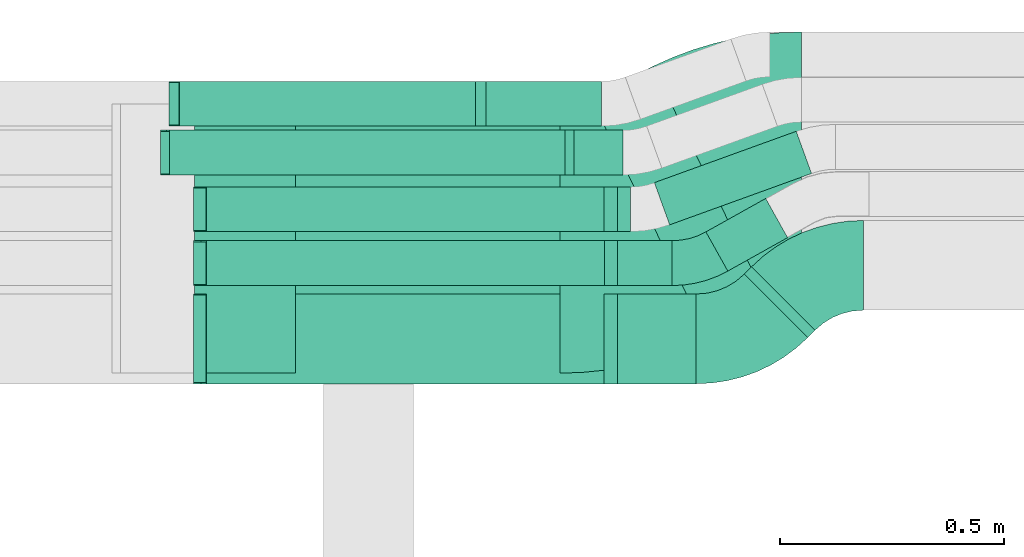
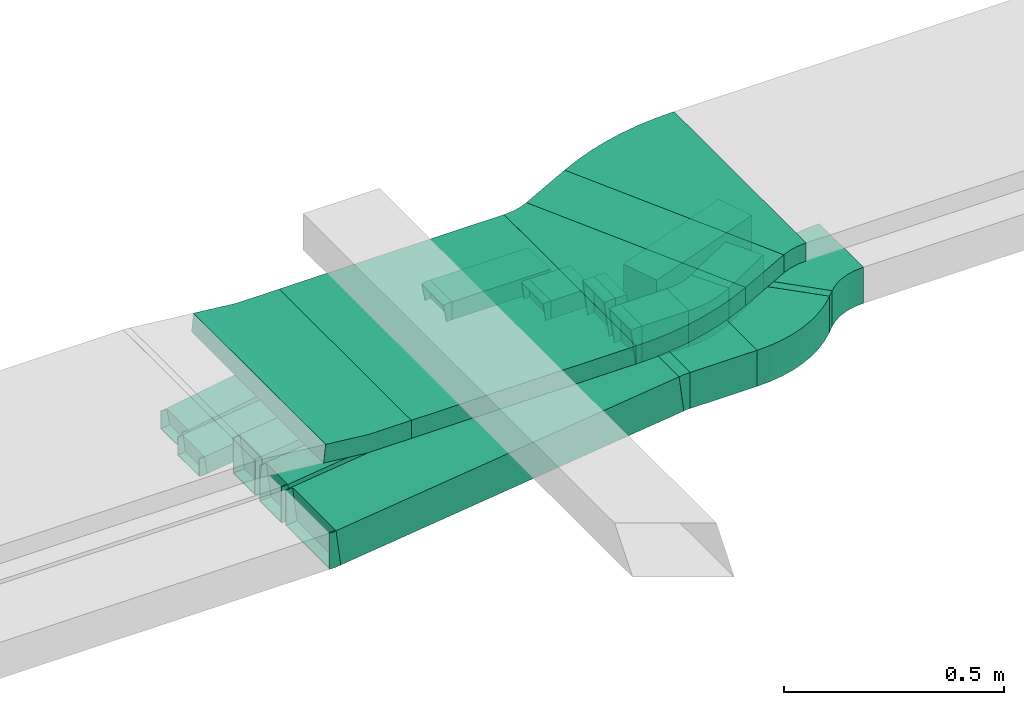
# One storey, part 26 of 38: 16 flow fittings, 15 flow segments.
"""IFC2X3 building model written with IfcOpenShell, lengths in millimetres."""

from ifc_helpers import new_model, entity, si_unit, converted_unit, derived_unit, direction, frame, frame_2d, origin, origin_2d_with_axis, place, context, subcontext, project, spatial, polyline, circle_curve, parameter, trimmed, segment, composite_curve, rectangle, outline, extrude, faceted_brep, source, transform, mapped, material, type_object, type_shapes, element, save


model = new_model("IFC2X3")

# Units and contexts
model_context = context("Model", 3, precision=0.01, world=origin(), true_north=direction((6.12303176911189e-17, 1.0)))
body_context = subcontext(model_context, "Body", "Model", "MODEL_VIEW")
ifc_project = project(units=[si_unit("LENGTHUNIT", "METRE", prefix="MILLI"), si_unit("AREAUNIT", "SQUARE_METRE"), si_unit("VOLUMEUNIT", "CUBIC_METRE"), converted_unit("PLANEANGLEUNIT", "DEGREE", entity("IfcRatioMeasure", 0.0174532925199433), si_unit("PLANEANGLEUNIT", "RADIAN"), dimensions=[0, 0, 0, 0, 0, 0, 0]), si_unit("MASSUNIT", "GRAM", prefix="KILO"), derived_unit("MASSDENSITYUNIT", [(si_unit("MASSUNIT", "GRAM", prefix="KILO"), 1), (si_unit("LENGTHUNIT", "METRE"), -3)]), derived_unit("MOMENTOFINERTIAUNIT", [(si_unit("LENGTHUNIT", "METRE"), 4)]), si_unit("TIMEUNIT", "SECOND"), si_unit("FREQUENCYUNIT", "HERTZ"), si_unit("THERMODYNAMICTEMPERATUREUNIT", "DEGREE_CELSIUS"), derived_unit("THERMALTRANSMITTANCEUNIT", [(si_unit("MASSUNIT", "GRAM", prefix="KILO"), 1), (si_unit("THERMODYNAMICTEMPERATUREUNIT", "KELVIN"), -1), (si_unit("TIMEUNIT", "SECOND"), -3)]), derived_unit("VOLUMETRICFLOWRATEUNIT", [(si_unit("LENGTHUNIT", "METRE"), 3), (si_unit("TIMEUNIT", "SECOND"), -1)]), derived_unit("MASSFLOWRATEUNIT", [(si_unit("MASSUNIT", "GRAM", prefix="KILO"), 1), (si_unit("TIMEUNIT", "SECOND"), -1)]), derived_unit("ROTATIONALFREQUENCYUNIT", [(si_unit("TIMEUNIT", "SECOND"), -1)]), si_unit("ELECTRICCURRENTUNIT", "AMPERE"), si_unit("ELECTRICVOLTAGEUNIT", "VOLT"), si_unit("POWERUNIT", "WATT"), si_unit("FORCEUNIT", "NEWTON", prefix="KILO"), si_unit("ILLUMINANCEUNIT", "LUX"), si_unit("LUMINOUSFLUXUNIT", "LUMEN"), si_unit("LUMINOUSINTENSITYUNIT", "CANDELA"), derived_unit("USERDEFINED", [(si_unit("MASSUNIT", "GRAM", prefix="KILO"), -1), (si_unit("LENGTHUNIT", "METRE"), -2), (si_unit("TIMEUNIT", "SECOND"), 3), (si_unit("LUMINOUSFLUXUNIT", "LUMEN"), 1)]), derived_unit("LINEARVELOCITYUNIT", [(si_unit("LENGTHUNIT", "METRE"), 1), (si_unit("TIMEUNIT", "SECOND"), -1)]), si_unit("PRESSUREUNIT", "PASCAL"), derived_unit("USERDEFINED", [(si_unit("LENGTHUNIT", "METRE"), -2), (si_unit("MASSUNIT", "GRAM", prefix="KILO"), 1), (si_unit("TIMEUNIT", "SECOND"), -2)]), derived_unit("LINEARFORCEUNIT", [(si_unit("MASSUNIT", "GRAM", prefix="KILO"), 1), (si_unit("LENGTHUNIT", "METRE"), 1), (si_unit("TIMEUNIT", "SECOND"), -2), (si_unit("LENGTHUNIT", "METRE"), -1)]), derived_unit("PLANARFORCEUNIT", [(si_unit("MASSUNIT", "GRAM", prefix="KILO"), 1), (si_unit("LENGTHUNIT", "METRE"), 1), (si_unit("TIMEUNIT", "SECOND"), -2), (si_unit("LENGTHUNIT", "METRE"), -2)])], contexts=[model_context])

# Site, building, storey
site_placement = place(None, frame((0.0, -0.00077364408347762, 0.0)))
site = spatial("IfcSite", under=ifc_project, at=site_placement, CompositionType="ELEMENT")
building_placement = place(site_placement, origin())
building = spatial("IfcBuilding", under=site, at=building_placement, CompositionType="ELEMENT")
storey_placement = place(building_placement, frame((0.0, 0.0, 4200.0)))
storey = spatial("IfcBuildingStorey", under=building, at=storey_placement, CompositionType="ELEMENT", Elevation=4200.0)

# Flow segments
cable_carrier_segment_type = type_object("IfcCableCarrierSegmentType", PredefinedType="CABLETRAYSEGMENT")
flow_segment_1_placement = place(storey_placement, frame((26151.9498084436, 15455.6878366683, 2793.21248393464)))
element("IfcFlowSegment", 1, at=flow_segment_1_placement, inside=storey, type_object=cable_carrier_segment_type, context=body_context, shape_type="SweptSolid", body=[
    extrude(rectangle(XDim=155.206153219677, YDim=600.0, at=origin_2d_with_axis()), frame((201.260527268146, 303.657163577565, 0.0), z_axis=(0.0, 0.0, 1.0), x_axis=(-0.898794046299167, -0.438371146789078, 0.0)), (0.0, 0.0, 1.0), 49.9999999999995),
])
flow_segment_2_placement = place(storey_placement, frame((25495.2448252932, 15379.3450002459, 2793.21248393464)))
element("IfcFlowSegment", 2, at=flow_segment_2_placement, inside=storey, type_object=cable_carrier_segment_type, context=body_context, shape_type="SweptSolid", body=[
    extrude(rectangle(XDim=589.05051708577, YDim=599.999999999998, at=frame_2d((2.18847162614111e-12, 0.0), x_axis=(1.0, 0.0))), frame((294.525258542883, 300.0, 0.0), z_axis=(0.0, 0.0, 1.0), x_axis=(-1.0, 0.0, 0.0)), (0.0, 0.0, 1.0), 49.9999999999995),
])
flow_segment_3_placement = place(storey_placement, frame((26495.4909974852, 15458.8827030652, 2639.20628594082)))
element("IfcFlowSegment", 3, at=flow_segment_3_placement, inside=storey, type_object=cable_carrier_segment_type, context=body_context, shape_type="SweptSolid", body=[
    extrude(rectangle(XDim=22.5844049492806, YDim=199.999999999995, at=frame_2d((-1.53121959556302e-12, 1.53477230924182e-12), x_axis=(1.0, 0.0))), frame((78.6954710630032, 78.6954710630032, 0.0), z_axis=(0.0, 0.0, 1.0), x_axis=(-0.707106781186596, -0.7071067811865, 0.0)), (0.0, 0.0, 1.0), 99.9999999999989),
])
flow_segment_4_placement = place(storey_placement, frame((26212.272261474, 15355.6629696993, 2639.20628594082)))
element("IfcFlowSegment", 4, at=flow_segment_4_placement, inside=storey, type_object=cable_carrier_segment_type, context=body_context, shape_type="SweptSolid", body=[
    extrude(rectangle(XDim=175.445612052065, YDim=200.000000000002, at=frame_2d((-2.16715534406831e-12, 2.16715534406831e-12), x_axis=(1.0, 0.0))), frame((87.7228060260303, 100.0, 0.0), z_axis=(0.0, 0.0, 1.0), x_axis=(-1.0, 0.0, 0.0)), (0.0, 0.0, 1.0), 99.9999999999989),
])
flow_segment_5_placement = place(storey_placement, frame((25284.2385665113, 15355.6629696993, 2526.29504881658)))
element("IfcFlowSegment", 5, at=flow_segment_5_placement, inside=storey, type_object=cable_carrier_segment_type, context=body_context, shape_type="SweptSolid", body=[
    extrude(rectangle(XDim=99.9999999999987, YDim=200.000000000002, at=frame_2d((-2.16715534406831e-12, 0.0), x_axis=(0.0, 1.0))), frame((6.17491527178125, 100.0, 49.6172391552196), z_axis=(0.992344783104405, 0.0, 0.123498305435627), x_axis=(0.0, 1.0, 0.0)), (0.0, 0.0, 1.0), 905.864321564183),
])
flow_segment_6_placement = place(storey_placement, frame((26212.802469336, 15574.4779321218, 2634.94591164699)))
element("IfcFlowSegment", 6, at=flow_segment_6_placement, inside=storey, type_object=cable_carrier_segment_type, context=body_context, shape_type="SweptSolid", body=[
    extrude(rectangle(XDim=121.812997004483, YDim=99.9999999999989, at=frame_2d((0.0, 2.16715534406831e-12), x_axis=(1.0, 0.0))), frame((60.9064985022415, 50.0, 0.0), z_axis=(0.0, 0.0, 1.0), x_axis=(-1.0, 0.0, 0.0)), (0.0, 0.0, 1.0), 99.9999999999989),
])
flow_segment_7_placement = place(storey_placement, frame((25284.2385665114, 15574.4779321218, 2521.96868962154)))
element("IfcFlowSegment", 7, at=flow_segment_7_placement, inside=storey, type_object=cable_carrier_segment_type, context=body_context, shape_type="SweptSolid", body=[
    extrude(rectangle(XDim=99.9999999999987, YDim=99.9999999999989, at=frame_2d((-2.16715534406831e-12, 0.0), x_axis=(0.0, 1.0))), frame((6.17491527178559, 50.0, 49.6172391552196), z_axis=(0.992344783104405, 0.0, 0.123498305435627), x_axis=(0.0, 1.0, 0.0)), (0.0, 0.0, 1.0), 906.398619593453),
])
flow_segment_8_placement = place(storey_placement, frame((26409.6750446795, 15606.7425305808, 2634.94591164699)))
element("IfcFlowSegment", 8, at=flow_segment_8_placement, inside=storey, type_object=cable_carrier_segment_type, context=body_context, shape_type="SweptSolid", body=[
    extrude(rectangle(XDim=152.623669799457, YDim=99.9999999999999, at=frame_2d((-5.25801624462474e-13, -9.37916411203332e-13), x_axis=(1.0, 0.0))), frame((91.0076473589663, 80.8780640835871, 0.0), z_axis=(0.0, 0.0, 1.0), x_axis=(0.87289325109934, 0.487911233919884, 0.0)), (0.0, 0.0, 1.0), 99.9999999999989),
])
flow_segment_9_placement = place(storey_placement, frame((26212.272261474, 15694.4779321217, 2639.20628594078)))
element("IfcFlowSegment", 9, at=flow_segment_9_placement, inside=storey, type_object=cable_carrier_segment_type, context=body_context, shape_type="SweptSolid", body=[
    extrude(rectangle(XDim=29.5976142987202, YDim=99.9999999999989, at=frame_2d((2.16626716564861e-12, -1.08357767203415e-12), x_axis=(1.0, 0.0))), frame((14.7988071493623, 50.0, 0.0), z_axis=(0.0, 0.0, 1.0), x_axis=(-1.0, 0.0, 0.0)), (0.0, 0.0, 1.0), 99.9999999999989),
])
flow_segment_10_placement = place(storey_placement, frame((25284.2385665113, 15694.4779321217, 2526.29504881656)))
element("IfcFlowSegment", 10, at=flow_segment_10_placement, inside=storey, type_object=cable_carrier_segment_type, context=body_context, shape_type="SweptSolid", body=[
    extrude(rectangle(XDim=100.000000000001, YDim=99.9999999999989, at=frame_2d((0.0, 0.0), x_axis=(0.0, 1.0))), frame((6.17491527178125, 50.0, 49.6172391552218), z_axis=(0.992344783104405, 0.0, 0.123498305435624), x_axis=(0.0, 1.0, 0.0)), (0.0, 0.0, 1.0), 905.864321564186),
])
flow_segment_11_placement = place(storey_placement, frame((26294.8445524544, 15709.7324984368, 2639.20628594031)))
element("IfcFlowSegment", 11, at=flow_segment_11_placement, inside=storey, type_object=cable_carrier_segment_type, context=body_context, shape_type="SweptSolid", body=[
    extrude(rectangle(XDim=336.229812926671, YDim=100.000000000002, at=frame_2d((-1.66267000167863e-12, 1.75859327100625e-12), x_axis=(1.0, 0.0))), frame((175.097061378085, 104.214681129726, 0.0), z_axis=(0.0, 0.0, 1.0), x_axis=(0.940342650313565, 0.340228893542658, 0.0)), (0.0, 0.0, 1.0), 99.9999999999989),
])
flow_segment_12_placement = place(storey_placement, frame((26115.7990911853, 15820.6629696994, 2639.20628594078)))
element("IfcFlowSegment", 12, at=flow_segment_12_placement, inside=storey, type_object=cable_carrier_segment_type, context=body_context, shape_type="SweptSolid", body=[
    extrude(rectangle(XDim=108.780385124798, YDim=99.9999999999989, at=frame_2d((-2.16715534406831e-12, 0.0), x_axis=(1.0, 0.0))), frame((54.3901925623968, 50.0, 0.0), z_axis=(0.0, 0.0, 1.0), x_axis=(-1.0, 0.0, 0.0)), (0.0, 0.0, 1.0), 50.0000000000005),
])
flow_segment_13_placement = place(storey_placement, frame((25208.3313547071, 15820.6629696994, 2525.75635310502)))
element("IfcFlowSegment", 13, at=flow_segment_13_placement, inside=storey, type_object=cable_carrier_segment_type, context=body_context, shape_type="SweptSolid", body=[
    extrude(rectangle(XDim=49.9999999999989, YDim=99.9999999999989, at=frame_2d((0.0, 0.0), x_axis=(0.0, 1.0))), frame((3.14632752693678, 50.0, 24.8012222096667), z_axis=(0.992048888386648, 0.0, 0.125853101077474), x_axis=(0.0, 1.0, 0.0)), (0.0, 0.0, 1.0), 894.551926158858),
])
flow_segment_14_placement = place(storey_placement, frame((25919.8036384505, 15929.5860181536, 2639.20628594077)))
element("IfcFlowSegment", 14, at=flow_segment_14_placement, inside=storey, type_object=cable_carrier_segment_type, context=body_context, shape_type="SweptSolid", body=[
    extrude(rectangle(XDim=257.337712334829, YDim=99.9999999999989, at=frame_2d((-2.1600499167107e-12, -1.08357767203415e-12), x_axis=(1.0, 0.0))), frame((128.668856167413, 50.0, 0.0), z_axis=(0.0, 0.0, 1.0), x_axis=(-1.0, 0.0, 0.0)), (0.0, 0.0, 1.0), 49.9999999999995),
])
flow_segment_15_placement = place(storey_placement, frame((25228.3825765326, 15929.5860181536, 2526.40625165384)))
element("IfcFlowSegment", 15, at=flow_segment_15_placement, inside=storey, type_object=cable_carrier_segment_type, context=body_context, shape_type="SweptSolid", body=[
    extrude(rectangle(XDim=50.0000000000004, YDim=99.9999999999989, at=frame_2d((-2.16715534406831e-12, 0.0), x_axis=(0.0, 1.0))), frame((4.11647804559661, 50.0, 24.6587633205767), z_axis=(0.986350532823018, 0.0, 0.16465912182369), x_axis=(0.0, 1.0, 0.0)), (0.0, 0.0, 1.0), 677.56498046901),
])

# Flow fittings
ifc_material = material()
cable_carrier_fitting_type_1 = type_object("IfcCableCarrierFittingType", Name="470_DKC_S5_Variable Angle Elbow 0-45:-", PredefinedType="NOTDEFINED", material=ifc_material)
shared_shape_1 = source(origin(), body_context, "Body", "SweptSolid", [
    extrude(outline(composite_curve([segment(polyline([(-99.6082065391294, -322.880932369381), (-98.6082065391277, -322.880932369381)]), True, "CONTINUOUS"), segment(trimmed(circle_curve(frame_2d((-98.6082065391032, 427.119067630618), x_axis=(0.0, -1.0)), 750.0), [parameter(0.0)], [parameter(26.0)], True, "PARAMETER"), True, "CONTINUOUS"), segment(polyline([(230.170153552683, -246.976467093767), (231.068947598979, -246.53809594698)]), True, "CONTINUOUS"), segment(polyline([(231.068947598979, -246.53809594698), (-31.9537404744441, 292.738331832532)]), True, "CONTINUOUS"), segment(polyline([(-31.9537404744441, 292.738331832532), (-32.852534520746, 292.299960685741)]), True, "CONTINUOUS"), segment(trimmed(circle_curve(frame_2d((-98.6082065391032, 427.119067630618), x_axis=(0.0, -1.0)), 150.0), [parameter(0.0)], [parameter(26.0)], True, "PARAMETER"), False, "CONTINUOUS"), segment(polyline([(-98.6082065391074, 277.119067630618), (-99.6082065391091, 277.119067630618)]), True, "CONTINUOUS"), segment(polyline([(-99.6082065391091, 277.119067630618), (-99.6082065391294, -322.880932369381)]), True, "CONTINUOUS")], self_intersect=False)), frame((-5.28247946737613, 22.8809323693768, -25.0)), (0.0, 0.0, 1.0), 50.0000000000037),
])
type_shapes(cable_carrier_fitting_type_1, [shared_shape_1])
flow_fitting_1_placement = place(storey_placement, frame((26189.1860283854, 15679.3450002459, 2818.21248393464)))
element("IfcFlowFitting", 16, at=flow_fitting_1_placement, inside=storey, type_object=cable_carrier_fitting_type_1, material=ifc_material, Name="470_DKC_S5_Variable Angle Elbow 0-45:-", ObjectType="470_DKC_S5_Variable Angle Elbow 0-45:-", context=body_context, shape_type="MappedRepresentation", body=[
    mapped(shared_shape_1, transform((0.0, 0.0, 0.0), scale=1.0)),
])
flow_fitting_2_placement = place(storey_placement, frame((26517.234643038, 15839.3450002458, 2818.21248393464), z_axis=(0.0, 0.0, 1.0), x_axis=(-1.0, 0.0, 0.0)))
element("IfcFlowFitting", 17, at=flow_fitting_2_placement, inside=storey, type_object=cable_carrier_fitting_type_1, material=ifc_material, Name="470_DKC_S5_Variable Angle Elbow 0-45:-", ObjectType="470_DKC_S5_Variable Angle Elbow 0-45:-", context=body_context, shape_type="MappedRepresentation", body=[
    mapped(shared_shape_1, transform((0.0, 0.0, 0.0), scale=1.0)),
])
cable_carrier_fitting_type_2 = type_object("IfcCableCarrierFittingType", Name="470_DKC_S5_CD 90 external vertical angle:-", PredefinedType="NOTDEFINED", material=ifc_material)
shared_shape_2 = source(origin(), body_context, "Body", "SweptSolid", [
    extrude(outline(composite_curve([segment(polyline([(-113.832583804587, -28.2221069581803), (-8.52066733028911, -28.2221069581803)]), True, "CONTINUOUS"), segment(trimmed(circle_curve(frame_2d((-8.52066733028938, 161.777893041818), x_axis=(0.0, -1.0)), 189.999999999999), [parameter(0.0)], [parameter(6.0298424485104)], True, "PARAMETER"), True, "CONTINUOUS"), segment(polyline([(11.4381571786587, -27.1708971745271), (116.167416195413, -16.1082547555193)]), True, "CONTINUOUS"), segment(polyline([(116.167416195413, -16.1082547555193), (110.915093956217, 33.615111090888)]), True, "CONTINUOUS"), segment(polyline([(110.915093956217, 33.615111090888), (6.18583493946174, 22.5524686718803)]), True, "CONTINUOUS"), segment(trimmed(circle_curve(frame_2d((-8.52066733028938, 161.777893041818), x_axis=(0.0, -1.0)), 139.999999999999), [parameter(0.0)], [parameter(6.0298424485104)], True, "PARAMETER"), False, "CONTINUOUS"), segment(polyline([(-8.52066733028911, 21.77789304182), (-113.832583804587, 21.7778930418199)]), True, "CONTINUOUS"), segment(polyline([(-113.832583804587, 21.7778930418199), (-113.832583804587, -28.2221069581803)]), True, "CONTINUOUS")], self_intersect=False)), frame((-0.169704902045645, 3.22210695817338, -300.0)), (0.0, 0.0, 1.0), 600.0),
])
type_shapes(cable_carrier_fitting_type_2, [shared_shape_2])
flow_fitting_3_placement = place(storey_placement, frame((25381.2425365865, 15679.3450002459, 2818.21248393468), z_axis=(0.0, -1.0, 0.0), x_axis=(0.994467316928114, 0.0, -0.105046444784187)))
element("IfcFlowFitting", 18, at=flow_fitting_3_placement, inside=storey, type_object=cable_carrier_fitting_type_2, material=ifc_material, Name="470_DKC_S5_CD 90 external vertical angle:-", ObjectType="470_DKC_S5_CD 90 external vertical angle:-", context=body_context, shape_type="MappedRepresentation", body=[
    mapped(shared_shape_2, transform((0.0, 0.0, 0.0), scale=1.0)),
])
cable_carrier_fitting_type_3 = type_object("IfcCableCarrierFittingType", Name="470_DKC_S5_Variable Angle Elbow 0-45:-", PredefinedType="NOTDEFINED", material=ifc_material)
shared_shape_3 = source(origin(), body_context, "Body", "SweptSolid", [
    extrude(outline(composite_curve([segment(polyline([(-89.3151243436159, -136.788429046978), (-88.3151243436146, -136.788429046978)]), True, "CONTINUOUS"), segment(trimmed(circle_curve(frame_2d((-88.315124343615, 213.211570953021), x_axis=(0.0, -1.0)), 350.0), [parameter(0.0)], [parameter(45.0)], True, "PARAMETER"), True, "CONTINUOUS"), segment(polyline([(159.172249071677, -34.2758024622698), (159.879355852863, -33.5686956810837)]), True, "CONTINUOUS"), segment(polyline([(159.879355852863, -33.5686956810837), (18.4579996155541, 107.852660556227)]), True, "CONTINUOUS"), segment(polyline([(18.4579996155541, 107.852660556227), (17.750892834367, 107.145553775039)]), True, "CONTINUOUS"), segment(trimmed(circle_curve(frame_2d((-88.315124343615, 213.211570953021), x_axis=(0.0, -1.0)), 150.0), [parameter(0.0)], [parameter(45.0)], True, "PARAMETER"), False, "CONTINUOUS"), segment(polyline([(-88.3151243436146, 63.2115709530216), (-89.3151243436159, 63.2115709530216)]), True, "CONTINUOUS"), segment(polyline([(-89.3151243436159, 63.2115709530216), (-89.3151243436159, -136.788429046978)]), True, "CONTINUOUS")], self_intersect=False)), frame((-15.238266249649, 36.7884290469702, -50.0)), (0.0, 0.0, 1.0), 100.0),
])
type_shapes(cable_carrier_fitting_type_3, [shared_shape_3])
flow_fitting_4_placement = place(storey_placement, frame((26656.1016729772, 15619.4933785571, 2689.20628594082), z_axis=(0.0, 0.0, 1.0), x_axis=(-1.0, 0.0, 0.0)))
element("IfcFlowFitting", 19, at=flow_fitting_4_placement, inside=storey, type_object=cable_carrier_fitting_type_3, material=ifc_material, Name="470_DKC_S5_Variable Angle Elbow 0-45:-", ObjectType="470_DKC_S5_Variable Angle Elbow 0-45:-", context=body_context, shape_type="MappedRepresentation", body=[
    mapped(shared_shape_3, transform((0.0, 0.0, 0.0), scale=1.0)),
])
flow_fitting_5_placement = place(storey_placement, frame((26492.2712641193, 15455.6629696993, 2689.20628594082)))
element("IfcFlowFitting", 20, at=flow_fitting_5_placement, inside=storey, type_object=cable_carrier_fitting_type_3, material=ifc_material, Name="470_DKC_S5_Variable Angle Elbow 0-45:-", ObjectType="470_DKC_S5_Variable Angle Elbow 0-45:-", context=body_context, shape_type="MappedRepresentation", body=[
    mapped(shared_shape_3, transform((0.0, 0.0, 0.0), scale=1.0)),
])
cable_carrier_fitting_type_4 = type_object("IfcCableCarrierFittingType", PredefinedType="NOTDEFINED", material=ifc_material)
shared_shape_4 = source(origin(), body_context, "Body", "Brep", [
    faceted_brep([(-11.5085733055393, -50.0, 100.0), (-11.508573305539, 50.0, 100.0), (-11.508573305539, 50.0, 97.4600000101635), (-11.5085733055393, -47.46000001016, 97.4600000101635), (-11.5085733055393, -47.46000001016, -97.4600000101564), (-11.508573305539, 50.0, -97.4600000101564), (-11.508573305539, 50.0, -100.0), (-11.5085733055393, -50.0, -100.0), (17.5953879525101, -48.1959498540043, 100.0), (17.5953879525101, -48.1959498540043, -100.0), (5.24555740894415, 51.0385284564358, -100.0), (5.24555740894415, 51.0385284564358, -97.4600000101564), (17.2817022579583, -45.6753941150014, -97.4600000101565), (17.2817022579583, -45.6753941150014, 97.4600000101635), (5.24555740894415, 51.0385284564358, 97.4600000101635), (5.24555740894415, 51.0385284564358, 100.0), (3.09932062168577, -50.0, 100.0), (-3.09932062168504, 50.0, 100.0), (-3.09932062168504, 50.0, 97.4600000101635), (2.94187513473391, -47.46000001016, 97.4600000101635), (2.94187513473391, -47.46000001016, -97.4600000101564), (-3.09932062168504, 50.0, -97.4600000101564), (-3.09932062168504, 50.0, -100.0), (3.09932062168574, -50.0, -100.0)], [[[0, 1, 2, 3, 4, 5, 6, 7]], [[8, 9, 10, 11, 12, 13, 14, 15]], [[1, 0, 16, 8, 15, 17]], [[2, 1, 17, 18]], [[3, 2, 18, 14, 13, 19]], [[4, 3, 19, 20]], [[5, 4, 20, 12, 11, 21]], [[6, 5, 21, 22]], [[7, 6, 22, 10, 9, 23]], [[0, 7, 23, 16]], [[18, 17, 15, 14]], [[20, 19, 13, 12]], [[22, 21, 11, 10]], [[16, 23, 9, 8]]]),
])
type_shapes(cable_carrier_fitting_type_4, [shared_shape_4])
for number, where, z_axis, x_axis in (
    (21, (25278.9930091024, 15455.6629696993, 2574.49099867058), (0.0, -1.0, 0.0), (1.0, 0.0, 0.0)),
    (22, (26200.7636881685, 15455.6629696993, 2689.20628594082), (0.0, -1.0, 0.0), (-1.0, 0.0, 0.0)),
):
    element("IfcFlowFitting", number, at=place(storey_placement, frame(where, z_axis=z_axis, x_axis=x_axis)), inside=storey, type_object=cable_carrier_fitting_type_4, material=ifc_material, context=body_context, shape_type="MappedRepresentation", body=[
        mapped(shared_shape_4, transform((0.0, 0.0, 0.0), scale=1.0)),
    ])
cable_carrier_fitting_type_5 = type_object("IfcCableCarrierFittingType", PredefinedType="NOTDEFINED", material=ifc_material)
shared_shape_5 = source(origin(), body_context, "Body", "Brep", [
    faceted_brep([(-11.5085733055393, -50.0, 50.0), (-11.508573305539, 50.0, 50.0), (-11.508573305539, 50.0, 47.4600000101635), (-11.5085733055393, -47.46000001016, 47.4600000101635), (-11.5085733055393, -47.46000001016, -47.4600000101565), (-11.508573305539, 50.0, -47.4600000101565), (-11.508573305539, 50.0, -50.0), (-11.5085733055393, -50.0, -50.0), (17.5953879525101, -48.1959498540043, 50.0), (17.5953879525101, -48.1959498540043, -50.0), (5.24555740894415, 51.0385284564358, -50.0), (5.24555740894415, 51.0385284564358, -47.4600000101565), (17.2817022579583, -45.6753941150014, -47.4600000101565), (17.2817022579583, -45.6753941150014, 47.4600000101635), (5.24555740894415, 51.0385284564358, 47.4600000101635), (5.24555740894415, 51.0385284564358, 50.0), (3.09932062168577, -50.0, 50.0), (-3.09932062168504, 50.0, 50.0), (-3.09932062168504, 50.0, 47.4600000101635), (2.94187513473391, -47.46000001016, 47.4600000101635), (2.94187513473391, -47.46000001016, -47.4600000101565), (-3.09932062168504, 50.0, -47.4600000101565), (-3.09932062168504, 50.0, -50.0), (3.09932062168574, -50.0, -50.0)], [[[0, 1, 2, 3, 4, 5, 6, 7]], [[8, 9, 10, 11, 12, 13, 14, 15]], [[1, 0, 16, 8, 15, 17]], [[2, 1, 17, 18]], [[3, 2, 18, 14, 13, 19]], [[4, 3, 19, 20]], [[5, 4, 20, 12, 11, 21]], [[6, 5, 21, 22]], [[7, 6, 22, 10, 9, 23]], [[0, 7, 23, 16]], [[18, 17, 15, 14]], [[20, 19, 13, 12]], [[22, 21, 11, 10]], [[16, 23, 9, 8]]]),
])
type_shapes(cable_carrier_fitting_type_5, [shared_shape_5])
for number, where, z_axis, x_axis in (
    (23, (26201.2938960305, 15624.4779321218, 2684.94591164699), (0.0, -1.0, 0.0), (-1.0, 0.0, 0.0)),
    (24, (26200.7636881685, 15744.4779321217, 2689.20628594079), (0.0, -1.0, 0.0), (-1.0, 0.0, 0.0)),
    (25, (25278.9930091024, 15624.4779321218, 2570.16463947554), (0.0, 1.0, 0.0), (-0.992344783104403, 0.0, -0.123498305435642)),
    (26, (25278.9930091024, 15744.4779321217, 2574.49099867057), (0.0, 1.0, 0.0), (-0.992344783104403, 0.0, -0.123498305435642)),
):
    element("IfcFlowFitting", number, at=place(storey_placement, frame(where, z_axis=z_axis, x_axis=x_axis)), inside=storey, type_object=cable_carrier_fitting_type_5, material=ifc_material, context=body_context, shape_type="MappedRepresentation", body=[
        mapped(shared_shape_5, transform((0.0, 0.0, 0.0), scale=1.0)),
    ])
cable_carrier_fitting_type_6 = type_object("IfcCableCarrierFittingType", Name="470_DKC_S5_Variable Angle Elbow 0-45:-", PredefinedType="NOTDEFINED", material=ifc_material)
shared_shape_6 = source(origin(), body_context, "Body", "SweptSolid", [
    extrude(outline(composite_curve([segment(polyline([(-49.7593467047495, -62.8326526985384), (-48.7593467047482, -62.8326526985384)]), True, "CONTINUOUS"), segment(trimmed(circle_curve(frame_2d((-48.7593467047507, 187.167347301461), x_axis=(0.0, -1.0)), 250.0), [parameter(0.0)], [parameter(29.2033852575725)], True, "PARAMETER"), True, "CONTINUOUS"), segment(polyline([(73.2184617751868, -31.0559654733922), (74.091355026286, -30.5680542394726)]), True, "CONTINUOUS"), segment(polyline([(74.091355026286, -30.5680542394726), (25.3002316343114, 56.7212708704691)]), True, "CONTINUOUS"), segment(polyline([(25.3002316343114, 56.7212708704691), (24.4273383832118, 56.2333596365492)]), True, "CONTINUOUS"), segment(trimmed(circle_curve(frame_2d((-48.7593467047507, 187.167347301461), x_axis=(0.0, -1.0)), 150.0), [parameter(0.0)], [parameter(29.2033852575725)], True, "PARAMETER"), False, "CONTINUOUS"), segment(polyline([(-48.759346704749, 37.1673473014614), (-49.7593467047503, 37.1673473014614)]), True, "CONTINUOUS"), segment(polyline([(-49.7593467047503, 37.1673473014614), (-49.7593467047495, -62.8326526985384)]), True, "CONTINUOUS")], self_intersect=False)), frame((-3.34306048084349, 12.83265269853, -50.0)), (0.0, 0.0, 1.0), 100.0),
])
type_shapes(cable_carrier_fitting_type_6, [shared_shape_6])
flow_fitting_6_placement = place(storey_placement, frame((26387.7178735261, 15624.4779321218, 2684.94591164699)))
element("IfcFlowFitting", 27, at=flow_fitting_6_placement, inside=storey, type_object=cable_carrier_fitting_type_6, material=ifc_material, Name="470_DKC_S5_Variable Angle Elbow 0-45:-", ObjectType="470_DKC_S5_Variable Angle Elbow 0-45:-", context=body_context, shape_type="MappedRepresentation", body=[
    mapped(shared_shape_6, transform((0.0, 0.0, 0.0), scale=1.0)),
])
cable_carrier_fitting_type_7 = type_object("IfcCableCarrierFittingType", PredefinedType="NOTDEFINED", material=ifc_material)
shared_shape_7 = source(origin(), body_context, "Body", "Brep", [
    faceted_brep([(-8.47477443933144, -25.0, 50.0), (-8.47477443933128, 25.0, 50.0), (-8.47477443933128, 25.0, 47.4600000101635), (-8.47477443933144, -22.46000001016, 47.4600000101635), (-8.47477443933144, -22.46000001016, -47.4600000101565), (-8.47477443933128, 25.0, -47.4600000101565), (-8.47477443933128, 25.0, -50.0), (-8.47477443933144, -25.0, -50.0), (11.5537180888057, -23.7346455655438, 50.0), (11.5537180888057, -23.7346455655438, -50.0), (5.26106303492828, 25.8677988537881, -50.0), (5.26106303492827, 25.8677988537881, -47.4600000101565), (11.2340512133474, -21.2148413991209, -47.4600000101565), (11.2340512133474, -21.2148413991209, 47.4600000101635), (5.26106303492828, 25.8677988537881, 47.4600000101635), (5.26106303492828, 25.8677988537881, 50.0), (1.57944292696933, -25.0, 50.0), (-1.57944292696858, 25.0, 50.0), (-1.57944292696858, 25.0, 47.4600000101635), (1.41897152623114, -22.46000001016, 47.4600000101635), (1.41897152623114, -22.46000001016, -47.4600000101565), (-1.57944292696858, 25.0, -47.4600000101565), (-1.57944292696858, 25.0, -50.0), (1.5794429269693, -25.0, -50.0)], [[[0, 1, 2, 3, 4, 5, 6, 7]], [[8, 9, 10, 11, 12, 13, 14, 15]], [[1, 0, 16, 8, 15, 17]], [[2, 1, 17, 18]], [[3, 2, 18, 14, 13, 19]], [[4, 3, 19, 20]], [[5, 4, 20, 12, 11, 21]], [[6, 5, 21, 22]], [[7, 6, 22, 10, 9, 23]], [[0, 7, 23, 16]], [[18, 17, 15, 14]], [[20, 19, 13, 12]], [[22, 21, 11, 10]], [[16, 23, 9, 8]]]),
])
type_shapes(cable_carrier_fitting_type_7, [shared_shape_7])
for number, where, z_axis, x_axis in (
    (28, (25203.0702916722, 15870.6629696994, 2549.49099867057), (0.0, -1.0, 0.0), (1.0, 0.0, 0.0)),
    (29, (26107.3243167459, 15870.6629696994, 2664.20628594078), (0.0, -1.0, 0.0), (-1.0, 0.0, 0.0)),
):
    element("IfcFlowFitting", number, at=place(storey_placement, frame(where, z_axis=z_axis, x_axis=x_axis)), inside=storey, type_object=cable_carrier_fitting_type_7, material=ifc_material, context=body_context, shape_type="MappedRepresentation", body=[
        mapped(shared_shape_7, transform((0.0, 0.0, 0.0), scale=1.0)),
    ])
cable_carrier_fitting_type_8 = type_object("IfcCableCarrierFittingType", PredefinedType="NOTDEFINED", material=ifc_material)
shared_shape_8 = source(origin(), body_context, "Body", "Brep", [
    faceted_brep([(-9.55924145847113, -25.0, 50.0), (-9.55924145847097, 25.0, 50.0), (-9.55924145847097, 25.0, 47.4600000101635), (-9.55924145847112, -22.46000001016, 47.4600000101635), (-9.55924145847112, -22.46000001016, -47.4600000101565), (-9.55924145847097, 25.0, -47.4600000101565), (-9.55924145847097, 25.0, -50.0), (-9.55924145847113, -25.0, -50.0), (13.5452409515401, -23.0847470167233, 50.0), (13.5452409515401, -23.0847470167233, -50.0), (5.3122848603551, 26.2327796244276, -50.0), (5.3122848603551, 26.2327796244276, -47.4600000101565), (13.1270067837809, -20.5794166733741, -47.4600000101565), (13.1270067837809, -20.5794166733741, 47.4600000101635), (5.3122848603551, 26.2327796244276, 47.4600000101635), (5.3122848603551, 26.2327796244276, 50.0), (2.07238248112371, -25.0, 50.0), (-2.07238248112295, 25.0, 50.0), (-2.07238248112295, 25.0, 47.4600000101635), (1.86182842188376, -22.46000001016, 47.4600000101635), (1.86182842188376, -22.46000001016, -47.4600000101565), (-2.07238248112295, 25.0, -47.4600000101565), (-2.07238248112295, 25.0, -50.0), (2.07238248112367, -25.0, -50.0)], [[[0, 1, 2, 3, 4, 5, 6, 7]], [[8, 9, 10, 11, 12, 13, 14, 15]], [[1, 0, 16, 8, 15, 17]], [[2, 1, 17, 18]], [[3, 2, 18, 14, 13, 19]], [[4, 3, 19, 20]], [[5, 4, 20, 12, 11, 21]], [[6, 5, 21, 22]], [[7, 6, 22, 10, 9, 23]], [[0, 7, 23, 16]], [[18, 17, 15, 14]], [[20, 19, 13, 12]], [[22, 21, 11, 10]], [[16, 23, 9, 8]]]),
])
type_shapes(cable_carrier_fitting_type_8, [shared_shape_8])
for number, where, z_axis, x_axis in (
    (30, (25223.0702916723, 15979.5860181536, 2549.49099867057), (0.0, -1.0, 0.0), (1.0, 0.0, 0.0)),
    (31, (25910.244396992, 15979.5860181537, 2664.20628594077), (0.0, 1.0, 0.0), (0.986350532823018, 0.0, 0.164659121823689)),
):
    element("IfcFlowFitting", number, at=place(storey_placement, frame(where, z_axis=z_axis, x_axis=x_axis)), inside=storey, type_object=cable_carrier_fitting_type_8, material=ifc_material, context=body_context, shape_type="MappedRepresentation", body=[
        mapped(shared_shape_8, transform((0.0, 0.0, 0.0), scale=1.0)),
    ])

save(model, "model.ifc")
